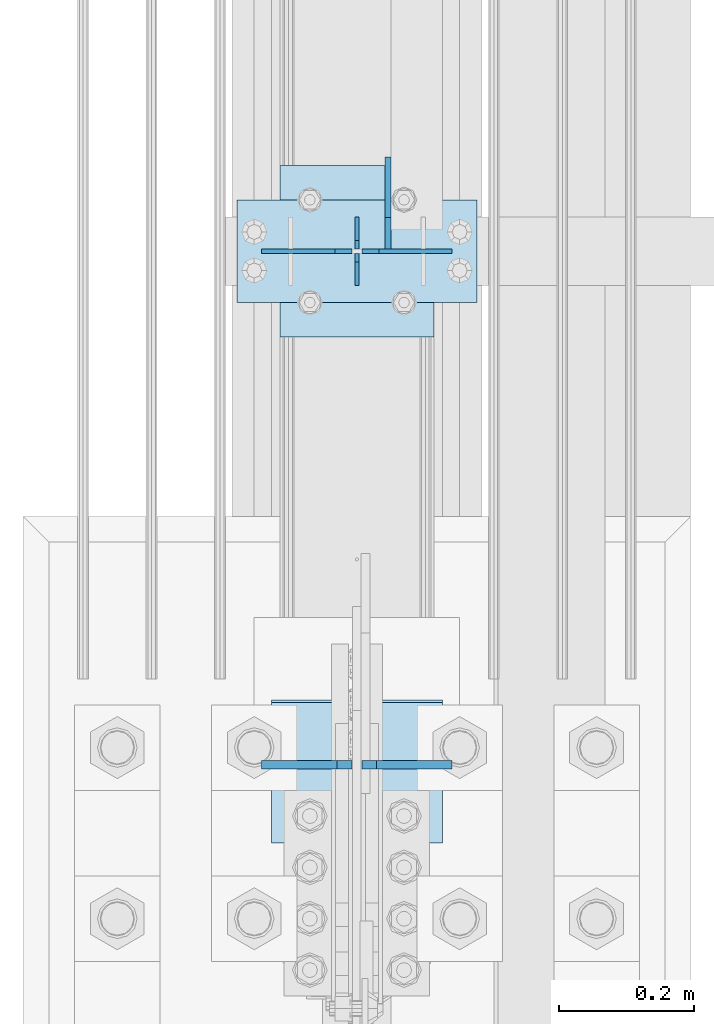
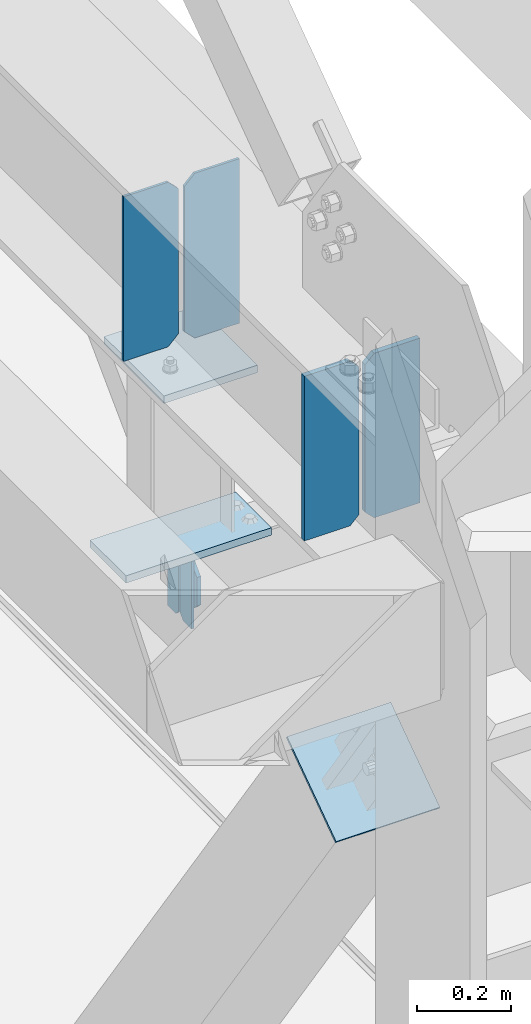
# One storey, part 3344 of 3843: 10 plates, 4 elements without a shape of their own.
"""IFC2X3 building model written with IfcOpenShell, lengths in millimetres."""

from ifc_helpers import new_model, si_unit, frame, origin_with_axes, place, context, subcontext, project, spatial, faceted_brep, material, type_object, element, aggregate, save


model = new_model("IFC2X3")

# Units and contexts
model_context = context("Model", 3, precision=1e-05, world=origin_with_axes())
body_context = subcontext(model_context, "Body", "Model", "MODEL_VIEW")
ifc_project = project(units=[si_unit("LENGTHUNIT", "METRE", prefix="MILLI"), si_unit("AREAUNIT", "SQUARE_METRE"), si_unit("VOLUMEUNIT", "CUBIC_METRE"), si_unit("MASSUNIT", "GRAM", prefix="KILO"), si_unit("TIMEUNIT", "SECOND"), si_unit("PLANEANGLEUNIT", "RADIAN"), si_unit("SOLIDANGLEUNIT", "STERADIAN"), si_unit("THERMODYNAMICTEMPERATUREUNIT", "DEGREE_CELSIUS"), si_unit("LUMINOUSINTENSITYUNIT", "LUMEN")], contexts=[model_context])

# Site, building, storey
site_placement = place(None, origin_with_axes())
site = spatial("IfcSite", under=ifc_project, at=site_placement, CompositionType="ELEMENT")
building_placement = place(site_placement, origin_with_axes())
building = spatial("IfcBuilding", under=site, at=building_placement, Name="Undefined", CompositionType="ELEMENT")
storey_placement = place(building_placement, origin_with_axes())
storey = spatial("IfcBuildingStorey", under=building, at=storey_placement, Name="Undefined", CompositionType="ELEMENT", Elevation=0.0)

# Assembly, plates
assembly_1_placement = place(storey_placement, origin_with_axes())
assembly_1 = element("IfcElementAssembly", 1, at=assembly_1_placement, inside=storey, Name="BEAM", AssemblyPlace="NOTDEFINED", PredefinedType="RIGID_FRAME")
ifc_material_1 = material(Name="STEEL/A572-50")
plate_type_1 = type_object("IfcPlateType", PredefinedType="NOTDEFINED")
plate_1_placement = place(assembly_1_placement, frame((36576.0000030517, 68694.3, 41495.6625), z_axis=(0.0, 0.0, -1.0), x_axis=(0.0, -1.0, 0.0)))
plate_1 = element("IfcPlate", 2, at=plate_1_placement, type_object=plate_type_1, material=ifc_material_1, Name="PLATE", context=body_context, shape_type="Brep", body=[
    faceted_brep([(0.0, -3.17499999999927, 0.0), (0.0, -3.17500000000291, 187.324999999997), (0.0, 3.17500000000291, 187.324999999997), (0.0, 3.17499999999927, 0.0), (34.9250001907349, -3.17500000000291, 187.324999999997), (34.9250001907349, 3.17500000000291, 187.324999999997), (47.625, -3.17500000000291, 174.625000190732), (47.625, 3.17500000000291, 174.625000190732), (47.625, -3.17499999999927, 12.6999998092651), (47.625, 3.17499999999927, 12.6999998092651), (34.9250001907349, -3.17499999999927, 0.0), (34.9250001907349, 3.17499999999927, 0.0)], [[[0, 1, 2, 3]], [[1, 4, 5, 2]], [[4, 6, 7, 5]], [[6, 8, 9, 7]], [[8, 10, 11, 9]], [[10, 0, 3, 11]], [[5, 7, 9, 11, 3, 2]], [[10, 8, 6, 4, 1, 0]]]),
])
plate_2_placement = place(assembly_1_placement, frame((36576.0000030517, 68592.7, 41495.6625), z_axis=(0.0, 0.0, -1.0), x_axis=(0.0, 1.0, 0.0)))
plate_2 = element("IfcPlate", 3, at=plate_2_placement, type_object=plate_type_1, material=ifc_material_1, Name="PLATE", context=body_context, shape_type="Brep", body=[
    faceted_brep([(0.0, -3.17499999999927, 0.0), (0.0, -3.17500000000291, 187.324999999997), (0.0, 3.17500000000291, 187.324999999997), (0.0, 3.17499999999927, 0.0), (34.9250001907349, -3.17500000000291, 187.324999999997), (34.9250001907349, 3.17500000000291, 187.324999999997), (47.625, -3.17500000000291, 174.625000190732), (47.625, 3.17500000000291, 174.625000190732), (47.625, -3.17499999999927, 12.6999998092651), (47.625, 3.17499999999927, 12.6999998092651), (34.9250001907349, -3.17499999999927, 0.0), (34.9250001907349, 3.17499999999927, 0.0)], [[[0, 1, 2, 3]], [[1, 4, 5, 2]], [[4, 6, 7, 5]], [[6, 8, 9, 7]], [[8, 10, 11, 9]], [[10, 0, 3, 11]], [[5, 7, 9, 11, 3, 2]], [[10, 8, 6, 4, 1, 0]]]),
])

assembly_2_placement = place(storey_placement, origin_with_axes())
assembly_2 = element("IfcElementAssembly", 4, at=assembly_2_placement, inside=storey, Name="BEAM", AssemblyPlace="NOTDEFINED", PredefinedType="RIGID_FRAME")
plate_type_2 = type_object("IfcPlateType", PredefinedType="NOTDEFINED")
plate_3_placement = place(assembly_2_placement, frame((36717.2875, 67881.6239134219, 42019.5375), z_axis=(0.0, 0.0, 1.0), x_axis=(-1.0, 0.0, 0.0)))
plate_3 = element("IfcPlate", 5, at=plate_3_placement, type_object=plate_type_2, material=ifc_material_1, Name="PLATE", context=body_context, shape_type="Brep", body=[
    faceted_brep([(0.0, -6.3499999046162, 0.0), (0.0, -6.34999999999854, 425.449999999997), (0.0, 6.34999999999854, 425.449999999997), (7.27595761418343e-12, 6.3499999046162, 0.0), (111.918749618526, -6.34999999999854, 425.449999999997), (111.918749618526, 6.34999999999854, 425.449999999997), (134.143749999996, -6.34999999999854, 403.224999618527), (134.143749999996, 6.34999999999854, 403.224999618527), (134.143749999996, -6.34999999999854, 22.2250003814697), (134.143749999996, 6.34999999999854, 22.2250003814697), (111.918749618526, -6.34999999999854, 0.0), (111.918749618526, 6.34999999999854, 0.0)], [[[0, 1, 2, 3]], [[1, 4, 5, 2]], [[4, 6, 7, 5]], [[6, 8, 9, 7]], [[8, 10, 11, 9]], [[10, 0, 3, 11]], [[5, 7, 9, 11, 3, 2]], [[10, 8, 6, 4, 1, 0]]]),
])
plate_4_placement = place(assembly_2_placement, frame((36568.85625, 67881.6239134219, 42019.5375), z_axis=(0.0, 0.0, 1.0), x_axis=(-1.0, 0.0, 0.0)))
plate_4 = element("IfcPlate", 6, at=plate_4_placement, type_object=plate_type_2, material=ifc_material_1, Name="PLATE", context=body_context, shape_type="Brep", body=[
    faceted_brep([(0.0, -6.34999999999854, 22.2250003814697), (0.0, -6.34999999999854, 403.224999618527), (0.0, 6.34999999999854, 403.224999618527), (-2.3032567586398e-12, 6.35, 22.2250003814697), (22.2250003814697, -6.34999999999854, 425.449999999997), (22.2250003814697, 6.34999999999854, 425.449999999997), (134.143749999996, -6.34999999999854, 425.449999999997), (134.143749999996, 6.34999999999854, 425.449999999997), (134.143749999996, -6.34999999999854, 0.0), (134.143749999996, 6.34999999999854, 0.0), (22.2250003814697, -6.34999999999854, 0.0), (22.2250003814697, 6.35, 0.0)], [[[0, 1, 2, 3]], [[1, 4, 5, 2]], [[4, 6, 7, 5]], [[6, 8, 9, 7]], [[8, 10, 11, 9]], [[10, 0, 3, 11]], [[5, 7, 9, 11, 3, 2]], [[10, 8, 6, 4, 1, 0]]]),
])

# Assembly, plate
assembly_3_placement = place(storey_placement, origin_with_axes())
assembly_3 = element("IfcElementAssembly", 7, at=assembly_3_placement, inside=storey, Name="POST", AssemblyPlace="NOTDEFINED", PredefinedType="RIGID_FRAME")
plate_type_3 = type_object("IfcPlateType", PredefinedType="NOTDEFINED")
plate_5_placement = place(assembly_3_placement, frame((36753.8000030518, 68567.3, 41513.125), z_axis=(-1.0, 0.0, 0.0), x_axis=(0.0, 1.0, 0.0)))
plate_5 = element("IfcPlate", 8, at=plate_5_placement, type_object=plate_type_3, material=ifc_material_1, Name="PLATE", context=body_context, shape_type="Brep", body=[
    faceted_brep([(0.0, -9.52500000000146, 0.0), (0.0, -9.52500000000146, 355.599999999999), (0.0, 9.52500000000146, 355.599999999999), (0.0, 9.52500000000146, 0.0), (152.399999999994, -9.52500000000146, 355.599999999999), (152.399999999994, 9.52500000000146, 355.599999999999), (152.400000000001, -9.52500000000146, 0.0), (152.400000000001, 9.52500000000146, 0.0)], [[[0, 1, 2, 3]], [[1, 4, 5, 2]], [[4, 6, 7, 5]], [[6, 0, 3, 7]], [[5, 7, 3, 2]], [[6, 4, 1, 0]]]),
])

assembly_4_placement = place(storey_placement, origin_with_axes())
assembly_4 = element("IfcElementAssembly", 9, at=assembly_4_placement, inside=storey, Name="Plate", AssemblyPlace="NOTDEFINED", PredefinedType="RIGID_FRAME")
ifc_material_2 = material(Name="STEEL/A36")
plate_type_4 = type_object("IfcPlateType", PredefinedType="NOTDEFINED")
plate_6_placement = place(assembly_4_placement, frame((36449.0, 67767.3447400026, 41301.4280400344), z_axis=(0.0, 0.819732546373636, 0.572746499261056), x_axis=(1.0, 0.0, 0.0)))
plate_6 = element("IfcPlate", 10, at=plate_6_placement, type_object=plate_type_4, material=ifc_material_2, Name="Plate", context=body_context, shape_type="Brep", body=[
    faceted_brep([(0.0, -3.17499999999927, 0.0), (0.0, -3.17499999965185, 254.000000005151), (0.0, 3.17500000035216, 254.000000005166), (0.0, 3.17499999999927, 0.0), (254.0, -3.17499999965185, 254.000000005151), (254.0, 3.17500000035216, 254.000000005166), (254.0, -3.17500000000291, 0.0), (254.0, 3.17499999999927, 1.45519152283669e-11)], [[[0, 1, 2, 3]], [[1, 4, 5, 2]], [[4, 6, 7, 5]], [[6, 0, 3, 7]], [[5, 7, 3, 2]], [[6, 4, 1, 0]]]),
])
aggregate(assembly_4, [plate_6])

# Plate
plate_type_5 = type_object("IfcPlateType", PredefinedType="NOTDEFINED")
plate_7_placement = place(assembly_3_placement, frame((36461.700000099, 68770.5, 41986.2), z_axis=(0.0, -1.0, 0.0), x_axis=(1.0, 0.0, 0.0)))
plate_7 = element("IfcPlate", 11, at=plate_7_placement, type_object=plate_type_5, material=ifc_material_1, Name="PLATE", context=body_context, shape_type="Brep", body=[
    faceted_brep([(0.0, -9.52500000000146, 0.0), (0.0, -9.52500000000146, 254.0), (0.0, 9.52500000000146, 254.0), (0.0, 9.52500000000146, 0.0), (228.599999999999, -9.52500000000146, 254.0), (228.599999999999, 9.52500000000146, 254.0), (228.599999999999, -9.52500000000146, 0.0), (228.599999999999, 9.52500000000146, 0.0)], [[[0, 1, 2, 3]], [[1, 4, 5, 2]], [[4, 6, 7, 5]], [[6, 0, 3, 7]], [[5, 7, 3, 2]], [[6, 4, 1, 0]]]),
])

aggregate(assembly_3, [plate_7, plate_5])

plate_type_6 = type_object("IfcPlateType", PredefinedType="NOTDEFINED")
plate_8_placement = place(assembly_1_placement, frame((36622.0375, 68646.675, 41306.75), z_axis=(0.0, 1.0, 0.0), x_axis=(0.0, 0.0, 1.0)))
plate_8 = element("IfcPlate", 12, at=plate_8_placement, type_object=plate_type_6, material=ifc_material_1, Name="PLATE", context=body_context, shape_type="Brep", body=[
    faceted_brep([(0.0, -4.76250000000073, 12.6999998092651), (4.450703272596e-08, -4.76249999999709, 93.0710244828806), (4.450703272596e-08, 4.76249999999709, 93.0710244828806), (0.0, 4.76250000000073, 12.6999998092651), (43.3137807601452, -4.76249999999709, 136.384805065652), (43.3137807601452, 4.76249999999709, 136.384805065652), (133.209805202001, -4.76249999999709, 46.4887805392646), (133.209805202001, 4.76249999999709, 46.4887805392646), (86.7210245267561, -4.76249999999709, 0.0), (86.7210245267561, 4.76249999999709, 0.0), (12.6999998092651, -4.76250000000073, 0.0), (12.6999998092651, 4.76250000000073, 0.0)], [[[0, 1, 2, 3]], [[1, 4, 5, 2]], [[4, 6, 7, 5]], [[6, 8, 9, 7]], [[8, 10, 11, 9]], [[10, 0, 3, 11]], [[5, 7, 9, 11, 3, 2]], [[10, 8, 6, 4, 1, 0]]]),
])

aggregate(assembly_1, [plate_1, plate_2, plate_8])

plate_type_7 = type_object("IfcPlateType", PredefinedType="NOTDEFINED")
plate_9_placement = place(assembly_2_placement, frame((36717.2875, 68643.5, 42444.9875), z_axis=(0.0, 0.0, -1.0), x_axis=(-1.0, 0.0, 0.0)))
plate_9 = element("IfcPlate", 13, at=plate_9_placement, type_object=plate_type_7, material=ifc_material_1, Name="PLATE", context=body_context, shape_type="Brep", body=[
    faceted_brep([(0.0, -3.17499999999927, 0.0), (0.0, -3.17500000000291, 425.449999999997), (0.0, 3.17500000000291, 425.449999999997), (0.0, 3.17499999999927, 0.0), (108.743750381465, -3.17500000000291, 425.449999999997), (108.743750381465, 3.17500000000291, 425.449999999997), (134.143749999996, -3.17500000000291, 400.050000381467), (134.143749999996, 3.17500000000291, 400.050000381467), (134.143749999996, -3.17500000000291, 25.3999996185303), (134.143749999996, 3.17500000000291, 25.3999996185303), (108.743750381465, -3.17500000000291, 0.0), (108.743750381465, 3.17500000000291, 0.0)], [[[0, 1, 2, 3]], [[1, 4, 5, 2]], [[4, 6, 7, 5]], [[6, 8, 9, 7]], [[8, 10, 11, 9]], [[10, 0, 3, 11]], [[5, 7, 9, 11, 3, 2]], [[10, 8, 6, 4, 1, 0]]]),
])

plate_10_placement = place(assembly_2_placement, frame((36434.7125, 68643.5, 42444.9875), z_axis=(0.0, 0.0, -1.0), x_axis=(1.0, 0.0, 0.0)))
plate_10 = element("IfcPlate", 14, at=plate_10_placement, type_object=plate_type_7, material=ifc_material_1, Name="PLATE", context=body_context, shape_type="Brep", body=[
    faceted_brep([(0.0, -3.17499999999927, 0.0), (0.0, -3.17500000000291, 425.449999999997), (0.0, 3.17500000000291, 425.449999999997), (0.0, 3.17499999999927, 0.0), (108.743750381465, -3.17500000000291, 425.449999999997), (108.743750381465, 3.17500000000291, 425.449999999997), (134.143749999996, -3.17500000000291, 400.050000381467), (134.143749999996, 3.17500000000291, 400.050000381467), (134.143749999996, -3.17500000000291, 25.3999996185303), (134.143749999996, 3.17500000000291, 25.3999996185303), (108.743750381465, -3.17500000000291, 0.0), (108.743750381465, 3.17500000000291, 0.0)], [[[0, 1, 2, 3]], [[1, 4, 5, 2]], [[4, 6, 7, 5]], [[6, 8, 9, 7]], [[8, 10, 11, 9]], [[10, 0, 3, 11]], [[5, 7, 9, 11, 3, 2]], [[10, 8, 6, 4, 1, 0]]]),
])

aggregate(assembly_2, [plate_3, plate_4, plate_9, plate_10])

save(model, "model.ifc")
